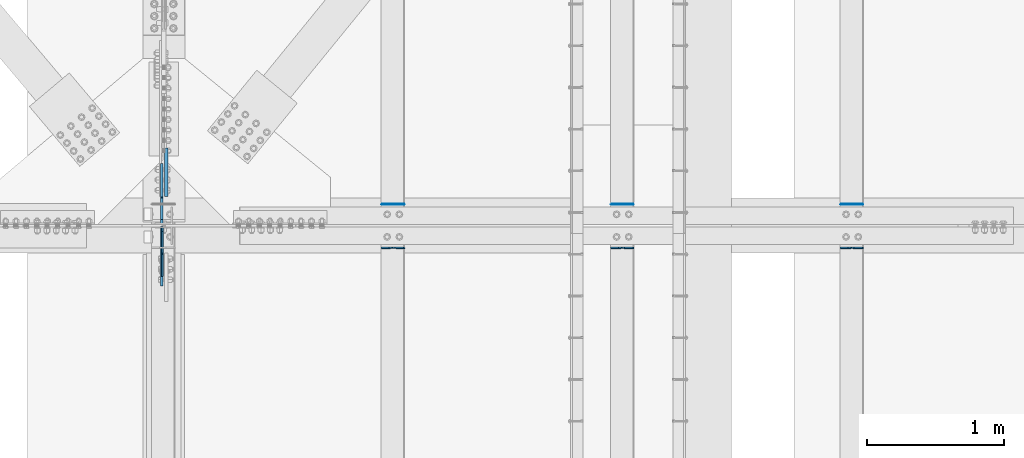
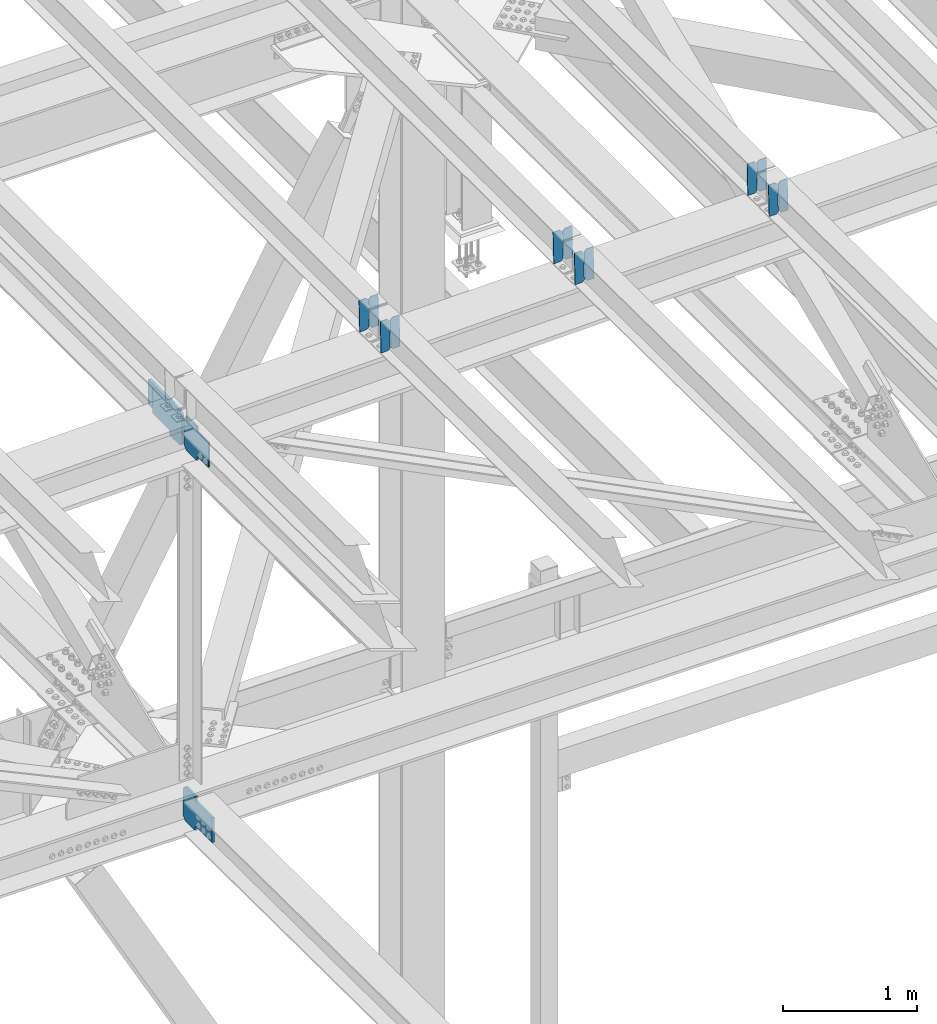
# One storey, part 3455 of 3843: 16 plates, 9 elements without a shape of their own.
"""IFC2X3 building model written with IfcOpenShell, lengths in millimetres."""

from ifc_helpers import new_model, si_unit, frame, origin_with_axes, place, context, subcontext, project, spatial, faceted_brep, material, type_object, element, aggregate, save


model = new_model("IFC2X3")

# Units and contexts
model_context = context("Model", 3, precision=1e-05, world=origin_with_axes())
body_context = subcontext(model_context, "Body", "Model", "MODEL_VIEW")
ifc_project = project(units=[si_unit("LENGTHUNIT", "METRE", prefix="MILLI"), si_unit("AREAUNIT", "SQUARE_METRE"), si_unit("VOLUMEUNIT", "CUBIC_METRE"), si_unit("MASSUNIT", "GRAM", prefix="KILO"), si_unit("TIMEUNIT", "SECOND"), si_unit("PLANEANGLEUNIT", "RADIAN"), si_unit("SOLIDANGLEUNIT", "STERADIAN"), si_unit("THERMODYNAMICTEMPERATUREUNIT", "DEGREE_CELSIUS"), si_unit("LUMINOUSINTENSITYUNIT", "LUMEN")], contexts=[model_context])

# Site, building, storey
site_placement = place(None, origin_with_axes())
site = spatial("IfcSite", under=ifc_project, at=site_placement, CompositionType="ELEMENT")
building_placement = place(site_placement, origin_with_axes())
building = spatial("IfcBuilding", under=site, at=building_placement, Name="Undefined", CompositionType="ELEMENT")
storey_placement = place(building_placement, origin_with_axes())
storey = spatial("IfcBuildingStorey", under=building, at=storey_placement, Name="Undefined", CompositionType="ELEMENT", Elevation=0.0)

# Assembly, plates
assembly_1_placement = place(storey_placement, origin_with_axes())
assembly_1 = element("IfcElementAssembly", 1, at=assembly_1_placement, inside=storey, Name="BEAM", AssemblyPlace="NOTDEFINED", PredefinedType="RIGID_FRAME")
ifc_material = material(Name="STEEL/A572-50")
plate_type_1 = type_object("IfcPlateType", PredefinedType="NOTDEFINED")
plate_1_placement = place(assembly_1_placement, frame((61042.2964783431, 84140.2777910002, 45958.6775913575), z_axis=(-0.0211520977430119, 0.00133068299971637, 0.999775383795693), x_axis=(-0.999776269352834, -2.81529999742652e-05, -0.0211520790074793)))
plate_1 = element("IfcPlate", 2, at=plate_1_placement, type_object=plate_type_1, material=ifc_material, Name="PLATE", context=body_context, shape_type="Brep", body=[
    faceted_brep([(0.0, -3.17499999999927, 0.0), (6.83940015733242e-10, -3.17499999996653, 288.924999998613), (6.54836185276508e-10, 3.17500000001746, 288.924999998591), (0.0, 3.17499999999927, 0.0), (60.3250007643655, -3.17500000017753, 288.924999998606), (60.3250007643219, 3.17499999979918, 288.924999998584), (79.3750000013097, -3.17500000025029, 269.875000761494), (79.375000001266, 3.17499999972642, 269.875000761487), (79.375000000713, -3.17500000026484, 19.0499992370605), (79.3750000006985, 3.17499999971187, 19.0499992370533), (60.325000763667, -3.17500000020664, -1.45519152283669e-11), (60.3250007636234, 3.17499999977736, -3.63797880709171e-11)], [[[0, 1, 2, 3]], [[1, 4, 5, 2]], [[4, 6, 7, 5]], [[6, 8, 9, 7]], [[8, 10, 11, 9]], [[10, 0, 3, 11]], [[5, 7, 9, 11, 3, 2]], [[10, 8, 6, 4, 1, 0]]]),
])
plate_2_placement = place(assembly_1_placement, frame((60956.5906576538, 84140.275377581, 45956.864329363), z_axis=(-0.0211520977430119, 0.00133068299971637, 0.999775383795693), x_axis=(-0.999776269352834, -2.81529999742652e-05, -0.0211520790074793)))
plate_2 = element("IfcPlate", 3, at=plate_2_placement, type_object=plate_type_1, material=ifc_material, Name="PLATE", context=body_context, shape_type="Brep", body=[
    faceted_brep([(4.36557456851006e-11, -3.17499999998836, 19.0499992370969), (6.11180439591408e-10, -3.17499999996653, 269.875000761516), (5.96628524363041e-10, 3.17500000001746, 269.875000761502), (1.45519152283669e-11, 3.17499999998836, 19.0499992370824), (19.0499992376572, -3.17500000003201, 288.924999998606), (19.0499992376281, 3.1749999999447, 288.924999998584), (79.3750000013242, -3.17500000025029, 288.924999998591), (79.3750000013097, 3.1749999997337, 288.92499999857), (79.3750000006548, -3.17500000026484, -2.18278728425503e-11), (79.3750000006403, 3.17499999969732, -2.91038304567337e-11), (19.0499992370023, -3.17500000005384, 0.0), (19.0499992369587, 3.17499999992287, -1.45519152283669e-11)], [[[0, 1, 2, 3]], [[1, 4, 5, 2]], [[4, 6, 7, 5]], [[6, 8, 9, 7]], [[8, 10, 11, 9]], [[10, 0, 3, 11]], [[5, 7, 9, 11, 3, 2]], [[10, 8, 6, 4, 1, 0]]]),
])
aggregate(assembly_1, [plate_1, plate_2])

assembly_2_placement = place(storey_placement, origin_with_axes())
assembly_2 = element("IfcElementAssembly", 4, at=assembly_2_placement, inside=storey, Name="BEAM", AssemblyPlace="NOTDEFINED", PredefinedType="RIGID_FRAME")
plate_3_placement = place(assembly_2_placement, frame((61042.2964783303, 83820.8493676964, 45960.1708819127), z_axis=(-0.0211520976666943, 0.00782973599719117, 0.999745609642029), x_axis=(-0.999776269357428, -0.0001656340000621, -0.0211514490075981)))
plate_3 = element("IfcPlate", 5, at=plate_3_placement, type_object=plate_type_1, material=ifc_material, Name="PLATE", context=body_context, shape_type="Brep", body=[
    faceted_brep([(0.0, -3.17499999999927, 0.0), (6.83940015733242e-10, -3.17499999996653, 288.924999998613), (6.54836185276508e-10, 3.17500000001746, 288.924999998591), (0.0, 3.17499999999927, 0.0), (60.3250007643655, -3.17500000017753, 288.924999998606), (60.3250007643219, 3.17499999979918, 288.924999998584), (79.3750000013097, -3.17500000025029, 269.875000761494), (79.375000001266, 3.17499999972642, 269.875000761487), (79.375000000713, -3.17500000026484, 19.0499992370605), (79.3750000006985, 3.17499999971187, 19.0499992370533), (60.325000763667, -3.17500000020664, -1.45519152283669e-11), (60.3250007636234, 3.17499999977736, -3.63797880709171e-11)], [[[0, 1, 2, 3]], [[1, 4, 5, 2]], [[4, 6, 7, 5]], [[6, 8, 9, 7]], [[8, 10, 11, 9]], [[10, 0, 3, 11]], [[5, 7, 9, 11, 3, 2]], [[10, 8, 6, 4, 1, 0]]]),
])
plate_4_placement = place(assembly_2_placement, frame((60956.590657641, 83820.8351671436, 45958.3576739185), z_axis=(-0.0211520976666943, 0.00782973599719117, 0.999745609642029), x_axis=(-0.999776269357428, -0.0001656340000621, -0.0211514490075981)))
plate_4 = element("IfcPlate", 6, at=plate_4_placement, type_object=plate_type_1, material=ifc_material, Name="PLATE", context=body_context, shape_type="Brep", body=[
    faceted_brep([(4.36557456851006e-11, -3.17499999998836, 19.0499992370969), (6.11180439591408e-10, -3.17499999996653, 269.875000761516), (5.96628524363041e-10, 3.17500000001746, 269.875000761502), (1.45519152283669e-11, 3.17499999998836, 19.0499992370824), (19.0499992376572, -3.17500000003201, 288.924999998606), (19.0499992376281, 3.1749999999447, 288.924999998584), (79.3750000013242, -3.17500000025029, 288.924999998591), (79.3750000013097, 3.1749999997337, 288.92499999857), (79.3750000006548, -3.17500000026484, -2.18278728425503e-11), (79.3750000006403, 3.17499999969732, -2.91038304567337e-11), (19.0499992370023, -3.17500000005384, 0.0), (19.0499992369587, 3.17499999992287, -1.45519152283669e-11)], [[[0, 1, 2, 3]], [[1, 4, 5, 2]], [[4, 6, 7, 5]], [[6, 8, 9, 7]], [[8, 10, 11, 9]], [[10, 0, 3, 11]], [[5, 7, 9, 11, 3, 2]], [[10, 8, 6, 4, 1, 0]]]),
])
aggregate(assembly_2, [plate_3, plate_4])

assembly_3_placement = place(storey_placement, origin_with_axes())
assembly_3 = element("IfcElementAssembly", 7, at=assembly_3_placement, inside=storey, Name="BEAM", AssemblyPlace="NOTDEFINED", PredefinedType="RIGID_FRAME")
plate_5_placement = place(assembly_3_placement, frame((59365.896478345, 84140.3051167846, 45922.4156081058), z_axis=(-0.0211520982558723, 0.0012391990004544, 0.999775501362787), x_axis=(-0.999776269341983, -2.62180000434616e-05, -0.0211520820072761)))
plate_5 = element("IfcPlate", 8, at=plate_5_placement, type_object=plate_type_1, material=ifc_material, Name="PLATE", context=body_context, shape_type="Brep", body=[
    faceted_brep([(0.0, -3.17499999999927, 0.0), (6.83940015733242e-10, -3.17499999996653, 288.924999998613), (6.54836185276508e-10, 3.17500000001746, 288.924999998591), (0.0, 3.17499999999927, 0.0), (60.3250007643655, -3.17500000017753, 288.924999998606), (60.3250007643219, 3.17499999979918, 288.924999998584), (79.3750000013097, -3.17500000025029, 269.875000761494), (79.375000001266, 3.17499999972642, 269.875000761487), (79.375000000713, -3.17500000026484, 19.0499992370605), (79.3750000006985, 3.17499999971187, 19.0499992370533), (60.325000763667, -3.17500000020664, -1.45519152283669e-11), (60.3250007636234, 3.17499999977736, -3.63797880709171e-11)], [[[0, 1, 2, 3]], [[1, 4, 5, 2]], [[4, 6, 7, 5]], [[6, 8, 9, 7]], [[8, 10, 11, 9]], [[10, 0, 3, 11]], [[5, 7, 9, 11, 3, 2]], [[10, 8, 6, 4, 1, 0]]]),
])
plate_6_placement = place(assembly_3_placement, frame((59280.1906576556, 84140.3028692881, 45920.6023458967), z_axis=(-0.0211520982558723, 0.0012391990004544, 0.999775501362787), x_axis=(-0.999776269341983, -2.62180000434616e-05, -0.0211520820072761)))
plate_6 = element("IfcPlate", 9, at=plate_6_placement, type_object=plate_type_1, material=ifc_material, Name="PLATE", context=body_context, shape_type="Brep", body=[
    faceted_brep([(4.36557456851006e-11, -3.17499999998836, 19.0499992370969), (6.11180439591408e-10, -3.17499999996653, 269.875000761516), (5.96628524363041e-10, 3.17500000001746, 269.875000761502), (1.45519152283669e-11, 3.17499999998836, 19.0499992370824), (19.0499992376572, -3.17500000003201, 288.924999998606), (19.0499992376281, 3.1749999999447, 288.924999998584), (79.3750000013242, -3.17500000025029, 288.924999998591), (79.3750000013097, 3.1749999997337, 288.92499999857), (79.3750000006548, -3.17500000026484, -2.18278728425503e-11), (79.3750000006403, 3.17499999969732, -2.91038304567337e-11), (19.0499992370023, -3.17500000005384, 0.0), (19.0499992369587, 3.17499999992287, -1.45519152283669e-11)], [[[0, 1, 2, 3]], [[1, 4, 5, 2]], [[4, 6, 7, 5]], [[6, 8, 9, 7]], [[8, 10, 11, 9]], [[10, 0, 3, 11]], [[5, 7, 9, 11, 3, 2]], [[10, 8, 6, 4, 1, 0]]]),
])
aggregate(assembly_3, [plate_5, plate_6])

assembly_4_placement = place(storey_placement, origin_with_axes())
assembly_4 = element("IfcElementAssembly", 10, at=assembly_4_placement, inside=storey, Name="BEAM", AssemblyPlace="NOTDEFINED", PredefinedType="RIGID_FRAME")
plate_7_placement = place(assembly_4_placement, frame((59365.8964817064, 83820.8934154694, 45923.8699121289), z_axis=(-0.0211520984461022, 0.00768082099843015, 0.999746764796024), x_axis=(-0.999776269343203, -0.000161584000118267, -0.0211514810072338)))
plate_7 = element("IfcPlate", 11, at=plate_7_placement, type_object=plate_type_1, material=ifc_material, Name="PLATE", context=body_context, shape_type="Brep", body=[
    faceted_brep([(0.0, -3.17499999999927, 0.0), (6.83940015733242e-10, -3.17499999996653, 288.924999998613), (6.54836185276508e-10, 3.17500000001746, 288.924999998591), (0.0, 3.17499999999927, 0.0), (60.3250007643655, -3.17500000017753, 288.924999998606), (60.3250007643219, 3.17499999979918, 288.924999998584), (79.3750000013097, -3.17500000025029, 269.875000761494), (79.375000001266, 3.17499999972642, 269.875000761487), (79.375000000713, -3.17500000026484, 19.0499992370605), (79.3750000006985, 3.17499999971187, 19.0499992370533), (60.325000763667, -3.17500000020664, -1.45519152283669e-11), (60.3250007636234, 3.17499999977736, -3.63797880709171e-11)], [[[0, 1, 2, 3]], [[1, 4, 5, 2]], [[4, 6, 7, 5]], [[6, 8, 9, 7]], [[8, 10, 11, 9]], [[10, 0, 3, 11]], [[5, 7, 9, 11, 3, 2]], [[10, 8, 6, 4, 1, 0]]]),
])
plate_8_placement = place(assembly_4_placement, frame((59280.1906610171, 83820.8794825995, 45922.0567020581), z_axis=(-0.0211520984461022, 0.00768082099843015, 0.999746764796024), x_axis=(-0.999776269343203, -0.000161584000118267, -0.0211514810072338)))
plate_8 = element("IfcPlate", 12, at=plate_8_placement, type_object=plate_type_1, material=ifc_material, Name="PLATE", context=body_context, shape_type="Brep", body=[
    faceted_brep([(4.36557456851006e-11, -3.17499999998836, 19.0499992370969), (6.11180439591408e-10, -3.17499999996653, 269.875000761516), (5.96628524363041e-10, 3.17500000001746, 269.875000761502), (1.45519152283669e-11, 3.17499999998836, 19.0499992370824), (19.0499992376572, -3.17500000003201, 288.924999998606), (19.0499992376281, 3.1749999999447, 288.924999998584), (79.3750000013242, -3.17500000025029, 288.924999998591), (79.3750000013097, 3.1749999997337, 288.92499999857), (79.3750000006548, -3.17500000026484, -2.18278728425503e-11), (79.3750000006403, 3.17499999969732, -2.91038304567337e-11), (19.0499992370023, -3.17500000005384, 0.0), (19.0499992369587, 3.17499999992287, -1.45519152283669e-11)], [[[0, 1, 2, 3]], [[1, 4, 5, 2]], [[4, 6, 7, 5]], [[6, 8, 9, 7]], [[8, 10, 11, 9]], [[10, 0, 3, 11]], [[5, 7, 9, 11, 3, 2]], [[10, 8, 6, 4, 1, 0]]]),
])
aggregate(assembly_4, [plate_7, plate_8])

assembly_5_placement = place(storey_placement, origin_with_axes())
assembly_5 = element("IfcElementAssembly", 13, at=assembly_5_placement, inside=storey, Name="BEAM", AssemblyPlace="NOTDEFINED", PredefinedType="RIGID_FRAME")
plate_9_placement = place(assembly_5_placement, frame((57689.4964783847, 84140.3324402429, 45886.1536353213), z_axis=(-0.0211520979448979, 0.00114771399952588, 0.999775610577246), x_axis=(-0.999776269348562, -2.42820000429985e-05, -0.0211520840073776)))
plate_9 = element("IfcPlate", 14, at=plate_9_placement, type_object=plate_type_1, material=ifc_material, Name="PLATE", context=body_context, shape_type="Brep", body=[
    faceted_brep([(0.0, -3.17499999999927, 0.0), (6.83940015733242e-10, -3.17499999996653, 288.924999998613), (6.54836185276508e-10, 3.17500000001746, 288.924999998591), (0.0, 3.17499999999927, 0.0), (60.3250007643655, -3.17500000017753, 288.924999998606), (60.3250007643219, 3.17499999979918, 288.924999998584), (79.3750000013097, -3.17500000025029, 269.875000761494), (79.375000001266, 3.17499999972642, 269.875000761487), (79.375000000713, -3.17500000026484, 19.0499992370605), (79.3750000006985, 3.17499999971187, 19.0499992370533), (60.325000763667, -3.17500000020664, -1.45519152283669e-11), (60.3250007636234, 3.17499999977736, -3.63797880709171e-11)], [[[0, 1, 2, 3]], [[1, 4, 5, 2]], [[4, 6, 7, 5]], [[6, 8, 9, 7]], [[8, 10, 11, 9]], [[10, 0, 3, 11]], [[5, 7, 9, 11, 3, 2]], [[10, 8, 6, 4, 1, 0]]]),
])
plate_10_placement = place(assembly_5_placement, frame((57603.7906576954, 84140.3303586692, 45884.3403729164), z_axis=(-0.0211520979448979, 0.00114771399952588, 0.999775610577246), x_axis=(-0.999776269348562, -2.42820000429985e-05, -0.0211520840073776)))
plate_10 = element("IfcPlate", 15, at=plate_10_placement, type_object=plate_type_1, material=ifc_material, Name="PLATE", context=body_context, shape_type="Brep", body=[
    faceted_brep([(4.36557456851006e-11, -3.17499999998836, 19.0499992370969), (6.11180439591408e-10, -3.17499999996653, 269.875000761516), (5.96628524363041e-10, 3.17500000001746, 269.875000761502), (1.45519152283669e-11, 3.17499999998836, 19.0499992370824), (19.0499992376572, -3.17500000003201, 288.924999998606), (19.0499992376281, 3.1749999999447, 288.924999998584), (79.3750000013242, -3.17500000025029, 288.924999998591), (79.3750000013097, 3.1749999997337, 288.92499999857), (79.3750000006548, -3.17500000026484, -2.18278728425503e-11), (79.3750000006403, 3.17499999969732, -2.91038304567337e-11), (19.0499992370023, -3.17500000005384, 0.0), (19.0499992369587, 3.17499999992287, -1.45519152283669e-11)], [[[0, 1, 2, 3]], [[1, 4, 5, 2]], [[4, 6, 7, 5]], [[6, 8, 9, 7]], [[8, 10, 11, 9]], [[10, 0, 3, 11]], [[5, 7, 9, 11, 3, 2]], [[10, 8, 6, 4, 1, 0]]]),
])
aggregate(assembly_5, [plate_9, plate_10])

assembly_6_placement = place(storey_placement, origin_with_axes())
assembly_6 = element("IfcElementAssembly", 16, at=assembly_6_placement, inside=storey, Name="BEAM", AssemblyPlace="NOTDEFINED", PredefinedType="RIGID_FRAME")
plate_11_placement = place(assembly_6_placement, frame((57689.4964816728, 83820.9554484027, 45887.5588443971), z_axis=(-0.0211520978175394, 0.00747113299851479, 0.999748353801913), x_axis=(-0.999776269351257, -0.000158092999964037, -0.0211515070074629)))
plate_11 = element("IfcPlate", 17, at=plate_11_placement, type_object=plate_type_1, material=ifc_material, Name="PLATE", context=body_context, shape_type="Brep", body=[
    faceted_brep([(0.0, -3.17499999999927, 0.0), (6.83940015733242e-10, -3.17499999996653, 288.924999998613), (6.54836185276508e-10, 3.17500000001746, 288.924999998591), (0.0, 3.17499999999927, 0.0), (60.3250007643655, -3.17500000017753, 288.924999998606), (60.3250007643219, 3.17499999979918, 288.924999998584), (79.3750000013097, -3.17500000025029, 269.875000761494), (79.375000001266, 3.17499999972642, 269.875000761487), (79.375000000713, -3.17500000026484, 19.0499992370605), (79.3750000006985, 3.17499999971187, 19.0499992370533), (60.325000763667, -3.17500000020664, -1.45519152283669e-11), (60.3250007636234, 3.17499999977736, -3.63797880709171e-11)], [[[0, 1, 2, 3]], [[1, 4, 5, 2]], [[4, 6, 7, 5]], [[6, 8, 9, 7]], [[8, 10, 11, 9]], [[10, 0, 3, 11]], [[5, 7, 9, 11, 3, 2]], [[10, 8, 6, 4, 1, 0]]]),
])
plate_12_placement = place(assembly_6_placement, frame((57603.7906609834, 83820.941895838, 45885.7456314444), z_axis=(-0.0211520978175394, 0.00747113299851479, 0.999748353801913), x_axis=(-0.999776269351257, -0.000158092999964037, -0.0211515070074629)))
plate_12 = element("IfcPlate", 18, at=plate_12_placement, type_object=plate_type_1, material=ifc_material, Name="PLATE", context=body_context, shape_type="Brep", body=[
    faceted_brep([(4.36557456851006e-11, -3.17499999998836, 19.0499992370969), (6.11180439591408e-10, -3.17499999996653, 269.875000761516), (5.96628524363041e-10, 3.17500000001746, 269.875000761502), (1.45519152283669e-11, 3.17499999998836, 19.0499992370824), (19.0499992376572, -3.17500000003201, 288.924999998606), (19.0499992376281, 3.1749999999447, 288.924999998584), (79.3750000013242, -3.17500000025029, 288.924999998591), (79.3750000013097, 3.1749999997337, 288.92499999857), (79.3750000006548, -3.17500000026484, -2.18278728425503e-11), (79.3750000006403, 3.17499999969732, -2.91038304567337e-11), (19.0499992370023, -3.17500000005384, 0.0), (19.0499992369587, 3.17499999992287, -1.45519152283669e-11)], [[[0, 1, 2, 3]], [[1, 4, 5, 2]], [[4, 6, 7, 5]], [[6, 8, 9, 7]], [[8, 10, 11, 9]], [[10, 0, 3, 11]], [[5, 7, 9, 11, 3, 2]], [[10, 8, 6, 4, 1, 0]]]),
])
aggregate(assembly_6, [plate_11, plate_12])

# Assembly, plate
assembly_7_placement = place(storey_placement, origin_with_axes())
assembly_7 = element("IfcElementAssembly", 19, at=assembly_7_placement, inside=storey, Name="BEAM", AssemblyPlace="NOTDEFINED", PredefinedType="RIGID_FRAME")
plate_type_2 = type_object("IfcPlateType", PredefinedType="NOTDEFINED")
plate_13_placement = place(assembly_7_placement, frame((55919.6874999833, 83973.987499991, 45513.1628903581), z_axis=(0.0, -0.707106781186682, 0.707106781186413), x_axis=(0.0, -0.707106781186548, -0.707106781186548)))
plate_13 = element("IfcPlate", 20, at=plate_13_placement, type_object=plate_type_2, material=ifc_material, Name="PLATE", context=body_context, shape_type="Brep", body=[
    faceted_brep([(0.0, -6.3499999046162, 0.0), (-179.46387894213, -6.35000000000582, 179.46387894213), (-179.46387894213, 6.35000000000582, 179.46387894213), (7.27595761418343e-12, 6.3499999046162, 0.0), (-179.463878941897, -6.35000000000582, 224.365159547495), (-179.463878941897, 6.35000000000582, 224.365159547495), (-68.3332094431244, -6.35000000000582, 335.495829046271), (-68.3332094431244, 6.35000000000582, 335.495829046271), (-47.433179093161, -6.34999999999854, 314.595798773738), (-47.433179093161, 6.34999999999854, 314.595798773738), (-43.3130026250001, -6.34999999999854, 311.842784873275), (-43.3130026250001, 6.34999999999854, 311.842784873275), (-38.452923106961, -6.34999999999854, 310.87605495071), (-38.452923106961, 6.34999999999854, 310.87605495071), (-33.5928435888927, -6.34999999999854, 311.842784873326), (-33.5928435888927, 6.34999999999854, 311.842784873326), (-29.4726671207172, -6.34999999999854, 314.595798773833), (-29.4726671207172, 6.34999999999854, 314.595798773833), (82.7805344921217, -6.34999999999854, 426.849000386646), (82.7805344921217, 6.34999999999854, 426.849000386646), (244.425144670575, -6.34999999999854, 265.204390208157), (244.425144670575, 6.34999999999854, 265.204390208157), (132.171943057736, -6.34999999999854, 152.951188595343), (132.171943057736, 6.34999999999854, 152.951188595343), (129.418929157226, -6.34999999999854, 148.831012127164), (129.418929157226, 6.34999999999854, 148.831012127164), (128.452199234613, -6.34999999999854, 143.970932609096), (128.452199234613, 6.34999999999854, 143.970932609096), (129.418929157182, -6.34999999999854, 139.11085309105), (129.418929157182, 6.34999999999854, 139.11085309105), (132.171943057649, -6.34999999999854, 134.990676622889), (132.171943057649, 6.34999999999854, 134.990676622889), (156.031950102829, -6.35000000000582, 111.130669497703), (156.031950102829, 6.35000000000582, 111.130669497703), (44.9012806051323, -6.35000000000582, -1.45519152283669e-11), (44.9012806051323, 6.35000000000582, -1.45519152283669e-11)], [[[0, 1, 2, 3]], [[1, 4, 5, 2]], [[4, 6, 7, 5]], [[6, 8, 9, 7]], [[8, 10, 11, 9]], [[10, 12, 13, 11]], [[12, 14, 15, 13]], [[14, 16, 17, 15]], [[16, 18, 19, 17]], [[18, 20, 21, 19]], [[20, 22, 23, 21]], [[22, 24, 25, 23]], [[24, 26, 27, 25]], [[26, 28, 29, 27]], [[28, 30, 31, 29]], [[30, 32, 33, 31]], [[32, 34, 35, 33]], [[34, 0, 3, 35]], [[5, 7, 9, 11, 13, 15, 17, 19, 21, 23, 25, 27, 29, 31, 33, 35, 3, 2]], [[34, 32, 30, 28, 26, 24, 22, 20, 18, 16, 14, 12, 10, 8, 6, 4, 1, 0]]]),
])

assembly_8_placement = place(storey_placement, origin_with_axes())
assembly_8 = element("IfcElementAssembly", 21, at=assembly_8_placement, inside=storey, Name="BEAM", AssemblyPlace="NOTDEFINED", PredefinedType="RIGID_FRAME")
plate_type_3 = type_object("IfcPlateType", PredefinedType="NOTDEFINED")
plate_14_placement = place(assembly_8_placement, frame((55916.5125625481, 83977.9562499789, 42128.8924707374), z_axis=(0.0, -0.707106781186682, 0.707106781186413), x_axis=(0.0, -0.707106781186548, -0.707106781186548)))
plate_14 = element("IfcPlate", 22, at=plate_14_placement, type_object=plate_type_3, material=ifc_material, Name="PLATE", context=body_context, shape_type="Brep", body=[
    faceted_brep([(0.0, -9.52500000000146, 0.0), (-179.598645145647, -9.52500000000146, 179.598645145648), (-179.598645145647, 9.52500000000146, 179.598645145648), (0.0, 9.52500000000146, 0.0), (-179.59864514565, -9.52500000000146, 224.499925750773), (-179.59864514565, 9.52500000000146, 224.499925750773), (-75.7644337462789, -9.52500000000146, 328.33413715013), (-75.7644337462789, 9.52500000000146, 328.33413715013), (-54.5587483177078, -9.52500000000146, 307.12845181816), (-54.5587483177078, 9.52500000000146, 307.12845181816), (-50.4385718495614, -9.52500000000146, 304.375437917686), (-50.4385718495614, 9.52500000000146, 304.375437917686), (-45.5784923315077, -9.52500000000146, 303.408707995131), (-45.5784923315077, 9.52500000000146, 303.408707995131), (-40.7184128134395, -9.52500000000146, 304.375437917737), (-40.7184128134395, 9.52500000000146, 304.375437917737), (-36.598236345264, -9.52500000000146, 307.128451818251), (-36.598236345264, 9.52500000000146, 307.128451818251), (134.026630047025, -9.52500000000146, 477.753318210496), (134.026630047025, 9.52500000000146, 477.753318210496), (295.671240225463, -9.52500000000146, 316.108708032018), (295.671240225463, 9.52500000000146, 316.108708032018), (125.046373833175, -9.52500000000146, 145.483841639765), (125.046373833175, 9.52500000000146, 145.483841639765), (122.293359932664, -9.52500000000146, 141.363665171586), (122.293359932664, 9.52500000000146, 141.363665171586), (121.326630010066, -9.52500000000146, 136.503585653529), (121.326630010066, 9.52500000000146, 136.503585653529), (122.293359932621, -9.52500000000146, 131.643506135464), (122.293359932621, 9.52500000000146, 131.643506135464), (125.046373833087, -9.52500000000146, 127.52332966731), (125.046373833087, 9.52500000000146, 127.52332966731), (148.735492003645, -9.52499999999418, 103.834211398527), (148.735492003645, 9.52499999999418, 103.834211398527), (44.9012806055835, -9.52499999999418, 4.65661287307739e-10), (44.9012806055835, 9.52499999999418, 4.65661287307739e-10)], [[[0, 1, 2, 3]], [[1, 4, 5, 2]], [[4, 6, 7, 5]], [[6, 8, 9, 7]], [[8, 10, 11, 9]], [[10, 12, 13, 11]], [[12, 14, 15, 13]], [[14, 16, 17, 15]], [[16, 18, 19, 17]], [[18, 20, 21, 19]], [[20, 22, 23, 21]], [[22, 24, 25, 23]], [[24, 26, 27, 25]], [[26, 28, 29, 27]], [[28, 30, 31, 29]], [[30, 32, 33, 31]], [[32, 34, 35, 33]], [[34, 0, 3, 35]], [[5, 7, 9, 11, 13, 15, 17, 19, 21, 23, 25, 27, 29, 31, 33, 35, 3, 2]], [[34, 32, 30, 28, 26, 24, 22, 20, 18, 16, 14, 12, 10, 8, 6, 4, 1, 0]]]),
])
aggregate(assembly_8, [plate_14])

# Plate
plate_15_placement = place(assembly_7_placement, frame((55916.512499659, 83996.2125, 45513.1628903755), z_axis=(0.0, 0.707106781186548, 0.707106781186548), x_axis=(5.70000238222118e-08, 0.707106781186546, -0.707106781186546)))
plate_15 = element("IfcPlate", 23, at=plate_15_placement, type_object=plate_type_3, material=ifc_material, Name="PLATE", context=body_context, shape_type="Brep", body=[
    faceted_brep([(0.0, -9.52500000000146, 0.0), (-179.366715657274, -9.52499999999418, 179.366715657248), (-179.366715657274, 9.52499999999418, 179.366715657248), (0.0, 9.52500000000146, 0.0), (-179.366715656826, -9.52499999999418, 224.267996262832), (-179.366715656826, 9.52499999999418, 224.267996262832), (-68.2360461568533, -9.52499999999418, 335.398665762827), (-68.2360461568533, 9.52499999999418, 335.398665762827), (-46.1232264977771, -9.52499999999418, 313.285846103783), (-46.1232264977771, 9.52499999999418, 313.285846103783), (-42.003050029638, -9.52499999999418, 310.532832203317), (-42.003050029638, 9.52499999999418, 310.532832203317), (-37.1429705115806, -9.52499999999418, 309.566102280762), (-37.1429705115806, 9.52499999999418, 309.566102280762), (-32.2828909935233, -9.52499999999418, 310.53283220336), (-32.2828909935233, 9.52499999999418, 310.53283220336), (-28.1627145253442, -9.52499999999418, 313.28584610387), (-28.1627145253442, 9.52499999999418, 313.28584610387), (142.462151912587, -9.52499999999418, 483.910712541838), (142.462151912587, 9.52499999999418, 483.910712541838), (304.106762091076, -9.52499999999418, 322.266102363385), (304.106762091076, 9.52499999999418, 322.266102363385), (133.481895653153, -9.52499999999418, 151.641235925432), (133.481895653153, 9.52499999999418, 151.641235925432), (130.728881752639, -9.52499999999418, 147.521059457242), (130.728881752639, 9.52499999999418, 147.521059457242), (129.762151830029, -9.52499999999418, 142.660979939188), (129.762151830029, 9.52499999999418, 142.660979939188), (130.728881752595, -9.52499999999418, 137.80090042112), (130.728881752595, 9.52499999999418, 137.80090042112), (133.481895653069, -9.52499999999418, 133.680723952973), (133.481895653069, 9.52499999999418, 133.680723952973), (156.031950102854, -9.52499999999418, 111.130669497732), (156.031950102854, 9.52499999999418, 111.130669497732), (44.9012806055835, -9.52499999999418, 4.65661287307739e-10), (44.9012806055835, 9.52499999999418, 4.65661287307739e-10)], [[[0, 1, 2, 3]], [[1, 4, 5, 2]], [[4, 6, 7, 5]], [[6, 8, 9, 7]], [[8, 10, 11, 9]], [[10, 12, 13, 11]], [[12, 14, 15, 13]], [[14, 16, 17, 15]], [[16, 18, 19, 17]], [[18, 20, 21, 19]], [[20, 22, 23, 21]], [[22, 24, 25, 23]], [[24, 26, 27, 25]], [[26, 28, 29, 27]], [[28, 30, 31, 29]], [[30, 32, 33, 31]], [[32, 34, 35, 33]], [[34, 0, 3, 35]], [[5, 7, 9, 11, 13, 15, 17, 19, 21, 23, 25, 27, 29, 31, 33, 35, 3, 2]], [[34, 32, 30, 28, 26, 24, 22, 20, 18, 16, 14, 12, 10, 8, 6, 4, 1, 0]]]),
])

aggregate(assembly_7, [plate_15, plate_13])

# Assembly, plate
assembly_9_placement = place(storey_placement, origin_with_axes())
assembly_9 = element("IfcElementAssembly", 24, at=assembly_9_placement, inside=storey, Name="BEAM", AssemblyPlace="NOTDEFINED", PredefinedType="RIGID_FRAME")
plate_type_4 = type_object("IfcPlateType", PredefinedType="NOTDEFINED")
plate_16_placement = place(assembly_9_placement, frame((55948.2625085503, 84553.4249947554, 45526.0034830239), z_axis=(0.0, -1.0, 0.0), x_axis=(0.0, 0.0, 1.0)))
plate_16 = element("IfcPlate", 25, at=plate_16_placement, type_object=plate_type_4, material=ifc_material, Name="PLATE", context=body_context, shape_type="Brep", body=[
    faceted_brep([(0.0, -12.6999999999971, 0.0), (0.0, -12.7000000000007, 355.600000000006), (0.0, 12.7000000000007, 355.600000000006), (0.0, 12.6999999999971, 0.0), (228.599998464349, -12.7000000013795, 355.599999691767), (228.599998464349, 12.6999999986292, 355.599999691869), (228.599999999991, -12.7000007629103, -5.82076609134674e-10), (228.59998398881, 12.6999999999971, -9.82254277914762e-10)], [[[0, 1, 2, 3]], [[1, 4, 5, 2]], [[4, 6, 7, 5]], [[6, 0, 3, 7]], [[5, 7, 3, 2]], [[6, 4, 1, 0]]]),
])
aggregate(assembly_9, [plate_16])

save(model, "model.ifc")
